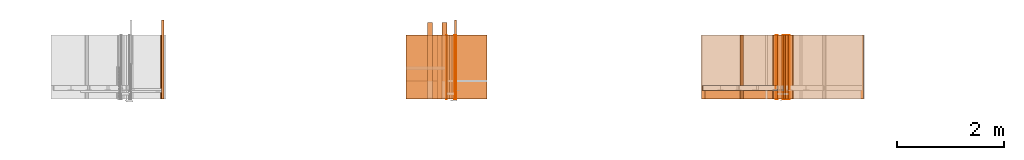
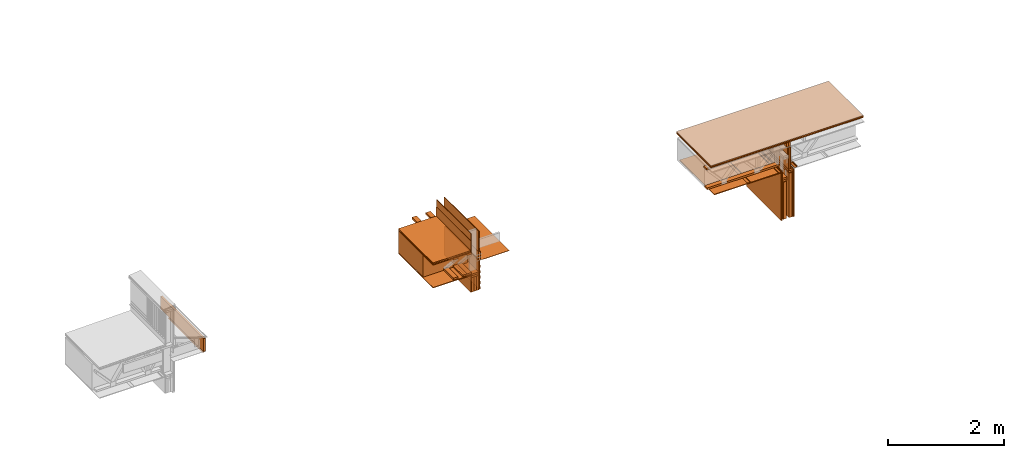
# One storey, part 4 of 22: 53 proxies.
"""IFC2X3 building model written with IfcOpenShell, lengths in feet."""

from ifc_helpers import new_model, entity, si_unit, converted_unit, frame, frame_2d, origin_with_axes, place, context, subcontext, project, spatial, polyline, rectangle, outline, extrude, element, save


model = new_model("IFC2X3")

# Units and contexts
model_context = context("Model", 3, precision=1e-05)
plan_context = context("Plan", 2, precision=1e-05, world=frame_2d((0.0, 0.0, 0.0), x_axis=(1.0, 0.0, 0.0)))
body_context_1 = subcontext(model_context, "Body", "Model", "MODEL_VIEW")
body_context_2 = subcontext(model_context, "Body", "Model", "MODEL_VIEW")
ifc_project = project(units=[converted_unit("VOLUMEUNIT", "cubic foot", entity("IfcReal", 0.0283168467116885), si_unit("VOLUMEUNIT", "CUBIC_METRE"), dimensions=[3, 0, 0, 0, 0, 0, 0]), converted_unit("AREAUNIT", "square foot", entity("IfcReal", 0.09290304), si_unit("AREAUNIT", "SQUARE_METRE"), dimensions=[2, 0, 0, 0, 0, 0, 0]), converted_unit("LENGTHUNIT", "foot", entity("IfcReal", 0.3048), si_unit("LENGTHUNIT", "METRE"), dimensions=[1, 0, 0, 0, 0, 0, 0])], contexts=[model_context, plan_context])

# Site, building, storey
site_placement = place(None, origin_with_axes())
site = spatial("IfcSite", under=ifc_project, at=site_placement, CompositionType="ELEMENT")
building_placement = place(site_placement, origin_with_axes())
building = spatial("IfcBuilding", under=site, at=building_placement, Name="Building", CompositionType="ELEMENT")
storey_placement = place(building_placement, origin_with_axes())
storey = spatial("IfcBuildingStorey", under=building, at=storey_placement, Name="Storey", CompositionType="ELEMENT")

# Proxies
proxy_1_placement = place(storey_placement, frame((1618.09265457113, 0.777434645675299, -60.9125365109581), z_axis=(0.0, 0.0, 1.0), x_axis=(1.0, 0.0, 0.0)))
element("IfcBuildingElementProxy", 1, at=proxy_1_placement, inside=storey, Name="Generic Models 857:Generic Models 1", context=body_context_1, shape_type="SweptSolid", body=[
    extrude(rectangle(XDim=4.86265082448443, YDim=0.124999990210441, at=frame_2d((0.0, 0.0, 0.0))), frame((-0.0624994935560727, 3.5449389241186, 0.0490916934441237), z_axis=(9.77766489995702e-08, -1.40081910711431e-14, -1.0), x_axis=(-1.43267257612933e-07, -1.0, 0.0)), (1.00845714001707e-08, 2.48565811489243e-07, -1.0), 0.887908264680847),
])
proxy_2_placement = place(storey_placement, frame((1617.96549799561, 1.89110167383209, -60.8823618550939), z_axis=(0.0, 0.0, 1.0), x_axis=(1.0, 0.0, 0.0)))
element("IfcBuildingElementProxy", 2, at=proxy_2_placement, inside=storey, Name="Vert", context=body_context_2, shape_type="SweptSolid", body=[
    extrude(outline(polyline([(0.00423777361432203, -0.0192872383032884), (0.10290118349897, -0.0192872383032884), (0.102901171276888, -0.0140460967660693), (0.00714266283457165, -0.0140460937105491), (-0.0136906679553466, 0.0192872367755283), (-0.0934482654776629, 0.0192872428865688), (-0.093448277699744, 0.0140460937105491), (-0.0165955587033564, 0.0140460967660693), (0.00423777361432203, -0.0192872383032884)])), frame((0.024263082766353, 3.92579930660919, -0.00037126060699912), z_axis=(0.0, 1.0, -5.34209793841001e-05), x_axis=(1.0, 0.0, -4.64536995536946e-08)), (4.39304799135232e-12, 5.34205901203677e-05, -1.0), 3.92582974397205),
])
proxy_3_placement = place(storey_placement, frame((1634.61059410115, 2.69422185389701, -61.9758708583401), z_axis=(0.0, 0.0, 1.0), x_axis=(-1.62920684942947e-07, 1.0, 0.0)))
element("IfcBuildingElementProxy", 3, at=proxy_3_placement, inside=storey, Name="Generic Models 855:Generic Models 1", context=body_context_1, shape_type="SweptSolid", body=[
    extrude(rectangle(XDim=4.70100164291481, YDim=0.291666664589754, at=frame_2d((0.0, 0.0, 0.0))), frame((1.54728593006535, 0.145833528651966, 1.70833482517032), z_axis=(0.0, 0.0, -1.0), x_axis=(1.0, 0.0, 0.0)), (0.0, 0.0, -1.0), 0.125000015272121),
])
proxy_4_placement = place(storey_placement, frame((1634.61059410115, 2.69422185389701, -61.6425354023931), z_axis=(0.0, 0.0, 1.0), x_axis=(-1.62920684942947e-07, 1.0, 0.0)))
element("IfcBuildingElementProxy", 4, at=proxy_4_placement, inside=storey, Name="Generic Models 855:Generic Models 1", context=body_context_1, shape_type="SweptSolid", body=[
    extrude(rectangle(XDim=4.70100164291481, YDim=0.291666664589754, at=frame_2d((0.0, 0.0, 0.0))), frame((1.54728593006535, 0.145833528651966, 0.0), z_axis=(0.0, 0.0, -1.0), x_axis=(1.0, 0.0, 0.0)), (0.0, 0.0, -1.0), 0.125000000235113),
])
proxy_5_placement = place(storey_placement, frame((1636.21777311711, 0.875491228472842, -58.3669457222846), z_axis=(0.0, 0.0, 1.0), x_axis=(1.0, 0.0, 0.0)))
element("IfcBuildingElementProxy", 5, at=proxy_5_placement, inside=storey, Name="Plane", context=body_context_1, shape_type="SweptSolid", body=[
    extrude(rectangle(XDim=0.0416667373353818, YDim=3.92583333372057, at=frame_2d((0.0, 0.0, 0.0))), frame((-0.729220980421452, 2.97847343242075, -1.71309029023478), z_axis=(0.0, 0.0, -1.0), x_axis=(-1.0, 0.0, 0.0)), (-7.93780046137726e-08, 0.0, -1.0), 1.23178509935517),
])
proxy_6_placement = place(storey_placement, frame((1635.25939300617, 0.875491228472842, -57.8051164081403), z_axis=(0.0, 0.0, 1.0), x_axis=(1.0, 0.0, 0.0)))
element("IfcBuildingElementProxy", 6, at=proxy_6_placement, inside=storey, Name="Plane", context=body_context_1, shape_type="SweptSolid", body=[
    extrude(rectangle(XDim=3.92583333372057, YDim=0.0416667373353818, at=frame_2d((0.0, 0.0, 0.0))), frame((0.729220980421452, 2.97847343242075, -2.46242118945585), z_axis=(0.0, 0.0, -1.0), x_axis=(0.0, -1.0, 0.0)), (0.0, 6.88914028046383e-08, -1.0), 1.41928670348369),
])
proxy_7_placement = place(storey_placement, frame((1632.20393063202, 1.89104789667555, -60.1425383660424), z_axis=(0.0, 0.0, 1.0), x_axis=(1.0, 0.0, 0.0)))
element("IfcBuildingElementProxy", 7, at=proxy_7_placement, inside=storey, Name="Generic Models 841:Generic Models 1:245", context=body_context_1, shape_type="SweptSolid", body=[
    extrude(rectangle(XDim=2.52925424444821, YDim=3.92583333372057, at=frame_2d((0.0, 0.0, 0.0))), frame((2.04088298354562, 1.96291666644139, 0.0), z_axis=(0.0, 0.0, -1.0), x_axis=(-1.0, 0.0, 0.0)), (0.0, 0.0, -1.0), 0.0625000001175565),
])
for number, where, z_axis, x_axis, name in (
    (8, (1635.96776526744, 1.8910506344217, -61.6425354023931), (0.0, 0.0, 1.0), (1.0, 0.0, 0.0), "Generic Models 857:Generic Models 1"),
    (9, (1635.96776526744, 1.8910506344217, -61.7675330695205), (0.0, 0.0, 1.0), (1.0, 0.0, 0.0), "Generic Models 857:Generic Models 1"),
):
    element("IfcBuildingElementProxy", number, at=place(storey_placement, frame(where, z_axis=z_axis, x_axis=x_axis)), inside=storey, Name=name, context=body_context_1, shape_type="SweptSolid", body=[
        extrude(rectangle(XDim=3.92583333372062, YDim=0.458337028879998, at=frame_2d((0.0, 0.0, 0.0))), frame((-0.22916851707018, 1.96291666644139, -0.124999744881169), z_axis=(2.39995301853924e-07, 1.5877549230936e-07, -1.0), x_axis=(0.0, 1.0, 1.5877549230936e-07)), (3.58418373105907e-13, 1.95553198523157e-07, -1.0), 0.125000025296795),
    ])
for number, where, z_axis, x_axis, name in (
    (10, (1635.8300957467, 1.891050829975, -62.7675331796561), (0.0, 0.0, 1.0), (1.0, 0.0, 0.0), "Generic Models 857:Generic Models 1"),
    (11, (1635.98258351404, 1.891050829975, -62.7675331796561), (0.0, 0.0, 1.0), (1.0, 0.0, 0.0), "Generic Models 857:Generic Models 1"),
    (12, (1636.13597239096, 1.891050829975, -62.7675331796561), (0.0, 0.0, 1.0), (1.0, 0.0, 0.0), "Generic Models 857:Generic Models 1"),
):
    element("IfcBuildingElementProxy", number, at=place(storey_placement, frame(where, z_axis=z_axis, x_axis=x_axis)), inside=storey, Name=name, context=body_context_1, shape_type="SweptSolid", body=[
        extrude(rectangle(XDim=3.92583333372062, YDim=0.152474618603812, at=frame_2d((0.0, 0.0, 0.0))), frame((-0.244431207420945, 1.96291666644139, -0.124999744881169), z_axis=(3.20632494776874e-07, 1.61888749516947e-07, -1.0), x_axis=(0.0, 1.0, 1.61888735306093e-07)), (-2.49453904643815e-07, 2.80553450693333e-07, -1.0), 1.00000000188097),
    ])
proxy_8_placement = place(storey_placement, frame((1635.25939300617, 0.875491228472842, -61.6011469382939), z_axis=(0.0, 0.0, 1.0), x_axis=(1.0, 0.0, 0.0)))
element("IfcBuildingElementProxy", 13, at=proxy_8_placement, inside=storey, Name="Plane", context=body_context_1, shape_type="SweptSolid", body=[
    extrude(rectangle(XDim=3.92583333372057, YDim=0.0416667373353818, at=frame_2d((0.0, 0.0, 0.0))), frame((0.729220980421452, 2.97847343242075, -1.29138547291593), z_axis=(0.0, 0.0, -1.0), x_axis=(0.0, 1.0, 0.0)), (0.0, -4.83804178941227e-08, -1.0), 2.0209963793876),
])
proxy_9_placement = place(storey_placement, frame((1632.24558191975, 1.8910506344217, -61.7362820883123), z_axis=(0.0, 0.0, 1.0), x_axis=(1.0, 0.0, 0.0)))
element("IfcBuildingElementProxy", 14, at=proxy_9_placement, inside=storey, Name="Generic Models 847:Generic Models 1:245", context=body_context_1, shape_type="SweptSolid", body=[
    extrude(rectangle(XDim=2.52916977314839, YDim=3.92583333372057, at=frame_2d((0.0, 0.0, 0.0))), frame((1.99918945630391, 1.96291666644139, 0.0), z_axis=(0.0, 0.0, -1.0), x_axis=(1.0, 0.0, 0.0)), (0.0, 0.0, -1.0), 0.0520833335148361),
])
proxy_10_placement = place(storey_placement, frame((1635.45733674618, 1.8910504388684, -63.2148777718932), z_axis=(0.0, 0.0, 1.0), x_axis=(1.0, 0.0, 0.0)))
element("IfcBuildingElementProxy", 15, at=proxy_10_placement, inside=storey, Name="Generic Models 845:Generic Models 1", context=body_context_1, shape_type="SweptSolid", body=[
    extrude(rectangle(XDim=3.92583333372062, YDim=0.0520833154704227, at=frame_2d((0.0, 0.0, 0.0))), frame((0.0260413466681411, 1.96291666644139, 0.322346925109703), z_axis=(0.0, 0.0, -1.0), x_axis=(1.63445363909887e-07, -1.0, 0.0)), (3.6811558246086e-09, 0.0, -1.0), 1.15625032746861),
])
proxy_11_placement = place(storey_placement, frame((1636.01442271956, 1.89101856368107, -60.8915669398671), z_axis=(0.0, 0.0, 1.0), x_axis=(1.0, 0.0, 0.0)))
element("IfcBuildingElementProxy", 16, at=proxy_11_placement, inside=storey, Name="Vert", context=body_context_2, shape_type="SweptSolid", body=[
    extrude(outline(polyline([(-0.0627850319241758, -0.0271161442519877), (0.120581120369941, -0.0271161442519877), (0.120581120369941, -0.0218750011870085), (-0.0575438858036763, -0.0218750011870085), (-0.0575438858036763, 0.0218750042425288), (-0.00025222097521066, 0.0218750042425288), (-0.00025222097521066, 0.0271161381409472), (-0.0627850319241758, 0.0271161381409472), (-0.0627850319241758, -0.0271161442519877)])), frame((0.0270833340754581, -4.1102113838438e-07, -0.0627715631908788), z_axis=(-3.93597567732717e-12, -1.0, -4.92744720759219e-06), x_axis=(0.0, 4.92744720759219e-06, -1.0)), (7.73744956994449e-10, -3.93597567732717e-12, -1.0), 3.92586307694604),
])
proxy_12_placement = place(storey_placement, frame((1635.08237503332, 0.875493770665697, -59.9454707048071), z_axis=(0.0, 0.0, 1.0), x_axis=(1.0, 0.0, 0.0)))
element("IfcBuildingElementProxy", 17, at=proxy_12_placement, inside=storey, Name="Plane", context=body_context_1, shape_type="SweptSolid", body=[
    extrude(rectangle(XDim=2.88351197437853, YDim=2.81717074082157, at=frame_2d((0.0, 0.0, 0.0))), frame((-0.660401668761346, 3.53280484207033, -1.69706332871294), z_axis=(0.0, 0.0, -1.0), x_axis=(1.0, 0.0, 0.0)), (0.0, 0.0, -1.0), 1.49999431547957),
])
proxy_13_placement = place(storey_placement, frame((1636.01962913053, 5.81688142511163, -63.8967924543566), z_axis=(0.0, -1.0, -1.62920684942947e-07), x_axis=(1.0, 0.0, 0.0)))
element("IfcBuildingElementProxy", 18, at=proxy_13_placement, inside=storey, Name="Plane", context=body_context_1, shape_type="SweptSolid", body=[
    extrude(outline(polyline([(-0.249999685315635, -0.0130000119060865), (0.24999939198569, -0.0130000073228061), (0.249999807536446, 0.0129999844064041), (-0.249999245320718, 0.0129999569067218), (-0.249999685315635, -0.0130000119060865)])), frame((0.0304482135374167, 2.75151720979395, -1.91897533617344e-05), z_axis=(-0.000177675639861263, -4.37063754361589e-05, -1.0), x_axis=(0.0697632730007172, -0.997563600540161, 3.12046613544226e-05)), (2.26211595872883e-05, 0.000180287868715823, -1.0), 3.9300003207006),
])
proxy_14_placement = place(storey_placement, frame((1636.00941655517, 1.89101856368107, -60.8915669398671), z_axis=(0.0, 0.0, 1.0), x_axis=(1.0, 0.0, 0.0)))
element("IfcBuildingElementProxy", 19, at=proxy_14_placement, inside=storey, Name="Vert", context=body_context_2, shape_type="SweptSolid", body=[
    extrude(outline(polyline([(-1.96293152849192, -0.00262057153248959), (1.96293152849192, -0.00262057153248959), (1.96293152849192, 0.00262057172345961), (-1.96293152849192, 0.00262057172345961), (-1.96293152849192, -0.00262057153248959)])), frame((0.00258776135595999, 1.96293152849192, -2.0009652757895), z_axis=(0.0, 0.0, -1.0), x_axis=(0.0, -1.0, 0.0)), (0.0, 0.0, -1.0), 2.02099423655302),
])
proxy_15_placement = place(storey_placement, frame((1634.96092548521, 1.89104789667555, -60.8915356513396), z_axis=(0.0, 0.0, 1.0), x_axis=(1.0, 0.0, 0.0)))
element("IfcBuildingElementProxy", 20, at=proxy_15_placement, inside=storey, Name="Generic Models 841:Generic Models 1:245", context=body_context_1, shape_type="SweptSolid", body=[
    extrude(rectangle(XDim=1.95334235530076, YDim=3.92583333372057, at=frame_2d((0.0, 0.0, 0.0))), frame((2.03011973010586, 1.96291666644139, 0.0), z_axis=(0.0, 0.0, -1.0), x_axis=(1.0, 0.0, 0.0)), (0.0, 0.0, -0.999999940395355), 0.0199999997321788),
])
proxy_16_placement = place(storey_placement, frame((1634.53039534762, 0.875502863893984, -58.0819322681177), z_axis=(-0.0622692182660103, -0.998051941394806, 0.00389242777600884), x_axis=(0.996106803417206, -0.0623907446861267, -0.06227657943964)))
element("IfcBuildingElementProxy", 21, at=proxy_16_placement, inside=storey, Name="Plane", context=body_context_1, shape_type="SweptSolid", body=[
    extrude(rectangle(XDim=0.0830000892507013, YDim=2.48751138231626, at=frame_2d((0.0, 0.0, 0.0))), frame((-0.491706053103049, -1.97191935355269, -4.92030867128547), z_axis=(-0.0623725615441799, 9.7108348029451e-08, -0.998052954673767), x_axis=(0.0622801221907139, -0.998051106929779, -0.0038922131061554)), (1.44668717894092e-06, -7.77533568907529e-06, -1.0), 3.92583022876836),
])
proxy_17_placement = place(storey_placement, frame((1632.19081448132, 1.89105493659422, -60.3577283423717), z_axis=(-0.0623933188617229, 0.998051643371582, -7.58967132696853e-07), x_axis=(-0.998051643371582, -0.0623933188617229, -1.47461420851869e-07)))
element("IfcBuildingElementProxy", 22, at=proxy_17_placement, inside=storey, Name="Generic Models 849:Generic Models 1", context=body_context_1, shape_type="SweptSolid", body=[
    extrude(outline(polyline([(-0.822174502169992, 0.213420341216673), (1.65544997832281, 0.213420341216673), (1.65482381666739, 0.223400721478024), (-0.832781019642597, 0.222774315380988), (-0.832648043400972, -0.436509081854282), (-0.822669154233507, -0.436506588549752), (-0.822174502169992, 0.213420341216673)])), frame((-2.43948630773489, 0.583672324034173, -0.152505049359767), z_axis=(0.0624201260507107, 1.42673263781035e-06, -0.998049974441528), x_axis=(0.998049974441528, 0.000251227029366419, 0.0624199658632278)), (1.3117592970957e-05, -1.32989362100489e-06, -1.0), 3.92583366091166),
])
proxy_18_placement = place(storey_placement, frame((1652.03174581052, 2.42488121423196, -61.6425354023931), z_axis=(0.0, 0.0, 1.0), x_axis=(1.0, 0.0, 0.0)))
element("IfcBuildingElementProxy", 23, at=proxy_18_placement, inside=storey, Name="Generic Models 855:Generic Models 1", context=body_context_1, shape_type="SweptSolid", body=[
    extrude(rectangle(XDim=4.68458124684587, YDim=0.291666664589754, at=frame_2d((0.0, 0.0, 0.0))), frame((1.53907582046479, 0.145833528651966, 0.0), z_axis=(0.0, 0.0, -1.0), x_axis=(1.0, 0.0, 0.0)), (0.0, 0.0, -1.0), 0.125000000235113),
])
proxy_19_placement = place(storey_placement, frame((1655.84704381587, 1.89104789667555, -62.3925401782739), z_axis=(0.0, 0.0, 1.0), x_axis=(-1.62920684942947e-07, 1.0, 0.0)))
element("IfcBuildingElementProxy", 24, at=proxy_19_placement, inside=storey, Name="Generic Models 857:Generic Models 1", context=body_context_1, shape_type="SweptSolid", body=[
    extrude(rectangle(XDim=0.291681873054029, YDim=3.92583333372057, at=frame_2d((0.0, 0.0, 0.0))), frame((1.96291666644139, -0.145840935233071, 0.125000001544871), z_axis=(0.0, 0.0, -1.0), x_axis=(0.0, 1.0, 0.0)), (0.0, 0.0, -1.0), 0.125000000235113),
])
proxy_20_placement = place(storey_placement, frame((1656.61949498134, 1.89104809222885, -61.6842117209447), z_axis=(0.0, 0.0, 1.0), x_axis=(-1.62920684942947e-07, 1.0, 0.0)))
element("IfcBuildingElementProxy", 25, at=proxy_20_placement, inside=storey, Name="Dowel60:Dowel", context=body_context_1, shape_type="SweptSolid", body=[
    extrude(outline(polyline([(-0.0601568078412002, 0.0312148619032516), (-0.00859693082641038, 0.0312148557922111), (0.0745830922986422, -0.0519651719161219), (0.0745830984096827, -0.0792705964815272), (0.0797914282426121, -0.0792705964815272), (0.0797914282426121, -0.049807809615933), (-0.00643956241518103, 0.036423191736181), (-0.0579994333189303, 0.0364231856251404), (-0.085936733362634, 0.0643604765022834), (-0.0896195763736729, 0.0606776334912445), (-0.0601568078412002, 0.0312148619032516)])), frame((7.80471796843667e-07, -0.112483185029092, 0.0211991903829215), z_axis=(-1.0, -2.10234720725566e-05, -1.15315469884081e-05), x_axis=(-6.7118080551154e-06, 0.70710676908493, -0.707106828689575)), (-5.45950661035022e-06, 2.0893143300782e-05, -1.0), 3.92583333463594),
])
proxy_21_placement = place(storey_placement, frame((1651.7534030704, 1.89104731001566, -61.6842117209447), z_axis=(0.0, 0.0, 1.0), x_axis=(-1.62920684942947e-07, 1.0, 0.0)))
element("IfcBuildingElementProxy", 26, at=proxy_21_placement, inside=storey, Name="Dowel60:Dowel", context=body_context_1, shape_type="SweptSolid", body=[
    extrude(outline(polyline([(-0.106276262287549, -0.0204650466415904), (-0.0646095319585068, -0.0204650466415904), (-0.0281511559065558, 0.0159932896885972), (0.0894831473941565, 0.0159932835775567), (0.108790906571497, -0.0033145642098714), (0.112473761804617, 0.000368273883689503), (0.0916404913612238, 0.0212016225770468), (-0.0303084998736231, 0.0212016195215265), (-0.0667668759255741, -0.0152567168086611), (-0.106276262287549, -0.0152567106976206), (-0.106276262287549, -0.0204650466415904)])), frame((3.92583411509596, -1.88752617735875, 0.0212016454934487), z_axis=(1.0, -1.44433724926785e-05, 5.75471631236724e-07), x_axis=(-9.38654284254881e-06, -1.0, -7.33323659574125e-08)), (7.52120149627444e-06, -5.71511520774948e-07, -1.0), 3.92583333383225),
])
proxy_22_placement = place(storey_placement, frame((1656.22210565202, 1.89104789667555, -62.0175471768917), z_axis=(0.0, 0.0, 1.0), x_axis=(-1.62920684942947e-07, 1.0, 0.0)))
element("IfcBuildingElementProxy", 27, at=proxy_22_placement, inside=storey, Name="Generic Models 857:Generic Models 1", context=body_context_1, shape_type="SweptSolid", body=[
    extrude(rectangle(XDim=0.291681873054029, YDim=3.92583333372057, at=frame_2d((0.0, 0.0, 0.0))), frame((1.96291666644139, -0.145840935233071, 0.125000001544871), z_axis=(0.0, 0.0, -1.0), x_axis=(0.0, 1.0, 0.0)), (0.0, 0.0, -1.0), 0.125000000235113),
])
proxy_23_placement = place(storey_placement, frame((1653.75336574444, 1.89104770112225, -61.6842117209447), z_axis=(0.0, 0.0, 1.0), x_axis=(-1.62920684942947e-07, 1.0, 0.0)))
element("IfcBuildingElementProxy", 28, at=proxy_23_placement, inside=storey, Name="Dowel60:Dowel", context=body_context_1, shape_type="SweptSolid", body=[
    extrude(outline(polyline([(-0.0916406685813988, -0.0212016195215265), (0.0303083257089684, -0.0212016195215265), (0.0667666987053991, 0.0152567152809009), (0.106276091178415, 0.0152567076421003), (0.106276091178415, 0.0204650435860701), (0.0646093547383318, 0.0204650451138303), (0.0281509817419011, -0.0159932896885972), (-0.0894833246143315, -0.0159932805220364), (-0.108791077680632, 0.00331456764733169), (-0.112473932913751, -0.000368270422357961), (-0.0916406685813988, -0.0212016195215265)])), frame((3.92583411509596, -1.88752617735875, 0.0212016454934487), z_axis=(1.0, -1.40156489578658e-05, -4.35728196634955e-07), x_axis=(1.28285309983767e-05, 1.0, 9.83910126706178e-08)), (-5.92708465774194e-06, -4.39525564388532e-07, -1.0), 3.92583333378991),
])
proxy_24_placement = place(storey_placement, frame((1655.80539252814, 0.875491326249491, -62.9761525652227), z_axis=(0.0, 0.0, 1.0), x_axis=(1.0, 0.0, 0.0)))
element("IfcBuildingElementProxy", 29, at=proxy_24_placement, inside=storey, Name="Plane", context=body_context_1, shape_type="SweptSolid", body=[
    extrude(rectangle(XDim=0.208333394207372, YDim=3.92583333372057, at=frame_2d((0.0, 0.0, 0.0))), frame((0.56250001306296, 2.97847343242075, -2.03039878465998), z_axis=(0.0, 0.0, -1.0), x_axis=(-1.0, 0.0, 0.0)), (0.0, 0.0, -1.0), 3.07234290048816),
])
proxy_25_placement = place(storey_placement, frame((1655.80539252814, 0.875491326249491, -63.4761557491433), z_axis=(0.0, 0.0, 1.0), x_axis=(1.0, 0.0, 0.0)))
element("IfcBuildingElementProxy", 30, at=proxy_25_placement, inside=storey, Name="Plane", context=body_context_1, shape_type="SweptSolid", body=[
    extrude(rectangle(XDim=0.208333334059344, YDim=3.92583333372057, at=frame_2d((0.0, 0.0, 0.0))), frame((0.187500020650428, 2.97847343242075, -1.53039560073943), z_axis=(0.0, 0.0, -1.0), x_axis=(-1.0, 0.0, 0.0)), (9.50269551935889e-09, 0.0, -1.0), 2.57233979441147),
])
proxy_26_placement = place(storey_placement, frame((1655.80539252814, 0.875491326249491, -62.9761525652227), z_axis=(0.0, 0.0, 1.0), x_axis=(1.0, 0.0, 0.0)))
element("IfcBuildingElementProxy", 31, at=proxy_26_placement, inside=storey, Name="Plane", context=body_context_1, shape_type="SweptSolid", body=[
    extrude(rectangle(XDim=3.92583333372057, YDim=0.0416666640300221, at=frame_2d((0.0, 0.0, 0.0))), frame((0.0208333437758794, 2.97847343242075, -2.07206552110006), z_axis=(0.0, 0.0, -1.0), x_axis=(0.0, -1.0, 0.0)), (0.0, 5.83169690315799e-09, -1.0), 3.40567790332094),
])
proxy_27_placement = place(storey_placement, frame((1655.84704381587, 1.89104789667555, -62.5175441031068), z_axis=(0.0, 0.0, 1.0), x_axis=(-1.62920684942947e-07, 1.0, 0.0)))
element("IfcBuildingElementProxy", 32, at=proxy_27_placement, inside=storey, Name="Generic Models 857:Generic Models 1", context=body_context_1, shape_type="SweptSolid", body=[
    extrude(rectangle(XDim=0.291681873054029, YDim=3.92583333372057, at=frame_2d((0.0, 0.0, 0.0))), frame((1.96291666644139, -0.145840935233071, 0.125000001544871), z_axis=(0.0, 0.0, -1.0), x_axis=(0.0, 1.0, 0.0)), (0.0, 0.0, -1.0), 0.125000000235113),
])
proxy_28_placement = place(storey_placement, frame((1655.80539252814, 0.875491326249491, -62.9761588229282), z_axis=(0.0, 0.0, 1.0), x_axis=(1.0, 0.0, 0.0)))
element("IfcBuildingElementProxy", 33, at=proxy_28_placement, inside=storey, Name="Plane", context=body_context_1, shape_type="SweptSolid", body=[
    extrude(rectangle(XDim=3.92583333372057, YDim=0.0416667373353818, at=frame_2d((0.0, 0.0, 0.0))), frame((0.729220980421452, 2.97847343242075, -2.07206552110006), z_axis=(0.0, 0.0, -1.0), x_axis=(0.0, 1.0, 0.0)), (0.0, -1.4354937682981e-08, -1.0), 3.40567997555669),
])
proxy_29_placement = place(storey_placement, frame((1655.75332841848, 1.89104789667555, -65.0482227796019), z_axis=(0.0, 0.0, 1.0), x_axis=(-1.62920684942947e-07, 1.0, 0.0)))
element("IfcBuildingElementProxy", 34, at=proxy_29_placement, inside=storey, Name="Generic Models 845:Generic Models 1", context=body_context_1, shape_type="SweptSolid", body=[
    extrude(rectangle(XDim=3.92583333372057, YDim=0.052083273366765, at=frame_2d((0.0, 0.0, 0.0))), frame((1.96291666644139, -0.82807121627287, 0.0), z_axis=(0.0, 0.0, -1.0), x_axis=(1.0, 0.0, 0.0)), (0.0, 0.0, -1.0), 3.31192968589252),
])
proxy_30_placement = place(storey_placement, frame((1652.54157359206, 1.89104789667555, -61.7362946037232), z_axis=(0.0, 0.0, 1.0), x_axis=(1.0, 0.0, 0.0)))
element("IfcBuildingElementProxy", 35, at=proxy_30_placement, inside=storey, Name="Generic Models 847:Generic Models 1:245", context=body_context_1, shape_type="SweptSolid", body=[
    extrude(rectangle(XDim=4.43001041812591, YDim=3.92583333372057, at=frame_2d((0.0, 0.0, 0.0))), frame((1.04876914675154, 1.96291666644139, 0.0), z_axis=(0.0, 0.0, -1.0), x_axis=(0.999999940395355, 0.0, 0.0)), (0.0, 0.0, -1.0), 0.0520833335148361),
])
proxy_31_placement = place(storey_placement, frame((1655.75332841848, 1.89104789667555, -65.0482227796019), z_axis=(0.0, 0.0, 1.0), x_axis=(-1.62920684942947e-07, 1.0, 0.0)))
element("IfcBuildingElementProxy", 36, at=proxy_31_placement, inside=storey, Name="Generic Models 845:Generic Models 1", context=body_context_1, shape_type="SweptSolid", body=[
    extrude(rectangle(XDim=3.92583333372057, YDim=0.0520833335148361, at=frame_2d((0.0, 0.0, 0.0))), frame((1.96291666644139, -0.0260416674977682, 0.0), z_axis=(0.0, 0.0, -1.0), x_axis=(1.0, 0.0, 0.0)), (0.0, 0.0, -1.0), 3.31192968589252),
])
proxy_32_placement = place(storey_placement, frame((1656.22210565202, 1.89104789667555, -61.8925432520589), z_axis=(0.0, 0.0, 1.0), x_axis=(-1.62920684942947e-07, 1.0, 0.0)))
element("IfcBuildingElementProxy", 37, at=proxy_32_placement, inside=storey, Name="Generic Models 857:Generic Models 1", context=body_context_1, shape_type="SweptSolid", body=[
    extrude(rectangle(XDim=0.291681873054029, YDim=3.92583333372057, at=frame_2d((0.0, 0.0, 0.0))), frame((1.96291666644139, -0.145840935233071, 0.125000001544871), z_axis=(0.0, 0.0, -1.0), x_axis=(0.0, -1.0, 0.0)), (0.0, 0.0, -1.0), 0.125000000235113),
])
proxy_33_placement = place(storey_placement, frame((1656.2115927068, 1.8910506344217, -59.8092091678009), z_axis=(0.0, 0.0, 1.0), x_axis=(1.0, 0.0, 0.0)))
element("IfcBuildingElementProxy", 38, at=proxy_33_placement, inside=storey, Name="Generic Models 857:Generic Models 1", context=body_context_1, shape_type="SweptSolid", body=[
    extrude(rectangle(XDim=3.92583333372062, YDim=0.103999983757077, at=frame_2d((0.0, 0.0, 0.0))), frame((0.0624996646652071, 1.96291666644139, -1.83333014565816), z_axis=(0.0, 0.0, -1.0), x_axis=(-1.61888735306093e-07, 1.0, 0.0)), (-6.74533007227751e-09, 1.62961075744761e-08, -0.999999940395355), 1.49999998277201),
])
proxy_34_placement = place(storey_placement, frame((1656.17004154235, 1.89104789667555, -63.5482132278402), z_axis=(0.0, 0.0, 1.0), x_axis=(-1.62920684942947e-07, 1.0, 0.0)))
element("IfcBuildingElementProxy", 39, at=proxy_34_placement, inside=storey, Name="Generic Models 845:Generic Models 1", context=body_context_1, shape_type="SweptSolid", body=[
    extrude(rectangle(XDim=3.92583333372057, YDim=0.0520833335148361, at=frame_2d((0.0, 0.0, 0.0))), frame((1.96291666644139, -0.0260416674977682, 2.90568419328825), z_axis=(0.0, 0.0, -1.0), x_axis=(1.0, 0.0, 0.0)), (0.0, 0.0, -1.0), 0.499992241783544),
])
proxy_35_placement = place(storey_placement, frame((1655.52414621268, 1.89104789667555, -63.5482132278402), z_axis=(0.0, 0.0, 1.0), x_axis=(-1.62920684942947e-07, 1.0, 0.0)))
element("IfcBuildingElementProxy", 40, at=proxy_35_placement, inside=storey, Name="Generic Models 845:Generic Models 1", context=body_context_1, shape_type="SweptSolid", body=[
    extrude(rectangle(XDim=3.92583333372057, YDim=0.052083273366765, at=frame_2d((0.0, 0.0, 0.0))), frame((1.96291666644139, -0.82807121627287, 1.90567156774165), z_axis=(0.0, 0.0, -1.0), x_axis=(1.0, 0.0, 0.0)), (0.0, 0.0, -1.0), 1.50000484807202),
])
for number, where, z_axis, x_axis, name in (
    (41, (1655.97269854208, 1.89105591436071, -59.7883459777031), (1.0, 4.01339377731347e-07, -4.01339264044509e-07), (-4.01339264044509e-07, 1.0, 2.68220873067548e-07), "Generic Models 857:Generic Models 1"),
    (42, (1656.09775252855, 1.89105591436071, -59.7883459777031), (1.0, 4.01339377731347e-07, -4.01339264044509e-07), (-4.01339264044509e-07, 1.0, 2.68220873067548e-07), "Generic Models 857:Generic Models 1"),
):
    element("IfcBuildingElementProxy", number, at=place(storey_placement, frame(where, z_axis=z_axis, x_axis=x_axis)), inside=storey, Name=name, context=body_context_1, shape_type="SweptSolid", body=[
        extrude(rectangle(XDim=0.291681873054029, YDim=3.92583333372057, at=frame_2d((0.0, 0.0, 0.0))), frame((1.96291666644139, -0.145840935233071, 0.125000001544871), z_axis=(0.0, 0.0, -1.0), x_axis=(0.0, -1.0, 0.0)), (0.0, 0.0, -1.0), 0.125000000235113),
    ])
for number, where, z_axis, x_axis, name in (
    (43, (1636.01962913053, 5.81688142511163, -64.2685001603574), (0.0, -1.0, -1.62920684942947e-07), (1.0, 0.0, 0.0), "Plane"),
    (44, (1636.01962913053, 5.81688142511163, -64.6394006223503), (0.0, -1.0, -1.62920684942947e-07), (1.0, 0.0, 0.0), "Plane"),
    (45, (1636.01962913053, 5.81688142511163, -65.0105201040353), (0.0, -1.0, -1.62920684942947e-07), (1.0, 0.0, 0.0), "Plane"),
    (46, (1636.01962913053, 5.81688142511163, -65.3818711208233), (0.0, -1.0, -1.62920684942947e-07), (1.0, 0.0, 0.0), "Plane"),
):
    element("IfcBuildingElementProxy", number, at=place(storey_placement, frame(where, z_axis=z_axis, x_axis=x_axis)), inside=storey, Name=name, context=body_context_1, shape_type="SweptSolid", body=[
        extrude(outline(polyline([(-0.249999685315635, -0.0130000119060865), (0.24999939198569, -0.0130000073228061), (0.249999807536446, 0.0129999844064041), (-0.249999245320718, 0.0129999569067218), (-0.249999685315635, -0.0130000119060865)])), frame((0.0304482135374167, 2.75151720979395, -1.91897533617344e-05), z_axis=(-0.000177675639861263, -4.37063754361589e-05, -1.0), x_axis=(0.0697632730007172, -0.997563600540161, 3.12046613544226e-05)), (2.26211595872883e-05, 0.000180287868715823, -1.0), 3.9300003207006),
    ])
proxy_36_placement = place(storey_placement, frame((1634.92608258105, 1.89104789667555, -61.7675330695205), z_axis=(0.0, 0.0, 1.0), x_axis=(-1.62920684942947e-07, 1.0, 0.0)))
element("IfcBuildingElementProxy", 47, at=proxy_36_placement, inside=storey, Name="Generic Models 857:Generic Models 1", context=body_context_1, shape_type="SweptSolid", body=[
    extrude(rectangle(XDim=0.291681873054029, YDim=3.92583333372057, at=frame_2d((0.0, 0.0, 0.0))), frame((1.96291666644139, -0.145840935233071, 0.125000001544871), z_axis=(0.0, 0.0, -1.0), x_axis=(0.0, 1.0, 0.0)), (0.0, 0.0, -1.0), 0.125000000235113),
])
proxy_37_placement = place(storey_placement, frame((1635.50940085584, 2.69422185389701, -61.9758708583401), z_axis=(0.0, 0.0, 1.0), x_axis=(-1.62920684942947e-07, 1.0, 0.0)))
element("IfcBuildingElementProxy", 48, at=proxy_37_placement, inside=storey, Name="Generic Models 855:Generic Models 1", context=body_context_1, shape_type="SweptSolid", body=[
    extrude(rectangle(XDim=4.70100164291481, YDim=0.291666664589754, at=frame_2d((0.0, 0.0, 0.0))), frame((1.54728593006535, 0.145833528651966, 1.70833482517032), z_axis=(0.0, 0.0, -1.0), x_axis=(-1.0, 0.0, 0.0)), (0.0, 0.0, -1.0), 0.125000015272121),
])
proxy_38_placement = place(storey_placement, frame((1635.50940085584, 2.69422185389701, -61.6425354023931), z_axis=(0.0, 0.0, 1.0), x_axis=(-1.62920684942947e-07, 1.0, 0.0)))
element("IfcBuildingElementProxy", 49, at=proxy_38_placement, inside=storey, Name="Generic Models 855:Generic Models 1", context=body_context_1, shape_type="SweptSolid", body=[
    extrude(rectangle(XDim=4.70100164291481, YDim=0.291666664589754, at=frame_2d((0.0, 0.0, 0.0))), frame((1.54728593006535, 0.145833528651966, 0.0), z_axis=(0.0, 0.0, -1.0), x_axis=(-1.0, 0.0, 0.0)), (0.0, 0.0, -1.0), 0.125000000235113),
])
proxy_39_placement = place(storey_placement, frame((1651.96586468714, 2.42488121423196, -60.2675360331698), z_axis=(0.0, 0.0, 1.0), x_axis=(1.0, 0.0, 0.0)))
element("IfcBuildingElementProxy", 50, at=proxy_39_placement, inside=storey, Name="Generic Models 855:Generic Models 1", context=body_context_1, shape_type="SweptSolid", body=[
    extrude(rectangle(XDim=5.05934271880333, YDim=0.291666664589754, at=frame_2d((0.0, 0.0, 0.0))), frame((1.72645655360435, 0.145833528651966, 0.0), z_axis=(0.0, 0.0, -1.0), x_axis=(-0.999999940395355, 0.0, 0.0)), (0.0, 0.0, -1.0), 0.125000000235113),
])
proxy_40_placement = place(storey_placement, frame((1654.30114025206, 1.89105591436071, -59.7883459777031), z_axis=(0.0, 0.0, 1.0), x_axis=(1.0, 0.0, 0.0)))
element("IfcBuildingElementProxy", 51, at=proxy_40_placement, inside=storey, Name="Generic Models 841:Generic Models 1:245", context=body_context_1, shape_type="SweptSolid", body=[
    extrude(rectangle(XDim=9.96871498681381, YDim=3.92583333372057, at=frame_2d((0.0, 0.0, 0.0))), frame((1.84589288053237, 1.96291666644139, 0.0), z_axis=(0.0, 0.0, -1.0), x_axis=(-1.0, 0.0, 0.0)), (0.0, 0.0, -1.0), 0.0625000001175565),
])
proxy_41_placement = place(storey_placement, frame((1656.62760496765, 0.875510979355789, -57.7277398797784), z_axis=(-0.0622692257165909, -0.998051822185516, 0.00389242731034756), x_axis=(0.996106803417206, -0.0623907595872879, -0.0622765868902206)))
element("IfcBuildingElementProxy", 52, at=proxy_41_placement, inside=storey, Name="Plane", context=body_context_1, shape_type="SweptSolid", body=[
    extrude(rectangle(XDim=0.0830001136070218, YDim=9.9687255397146, at=frame_2d((0.0, 0.0, 0.0))), frame((-0.665142662881866, -1.98278370804674, -4.90946680542052), z_axis=(-0.0623861886560917, -7.75410853748326e-07, -0.998052060604095), x_axis=(-0.0622848160564899, 0.998050808906555, 0.00389221217483282)), (-1.77785875621339e-06, -6.0070105973864e-06, -1.0), 3.92583055557273),
])
proxy_42_placement = place(storey_placement, frame((1636.09271913063, 0.777434450122002, -60.8390022137659), z_axis=(0.0, 0.0, 1.0), x_axis=(1.0, 0.0, 0.0)))
element("IfcBuildingElementProxy", 53, at=proxy_42_placement, inside=storey, Name="Generic Models 857:Generic Models 1", context=body_context_1, shape_type="SweptSolid", body=[
    extrude(rectangle(XDim=4.86265082448525, YDim=0.124999990210441, at=frame_2d((0.0, 0.0, 0.0))), frame((-0.0624994935560727, 3.5449389241186, -0.0325324083495093), z_axis=(1.22221237575104e-07, -5.79980962811533e-07, -1.0), x_axis=(-1.43267257612933e-07, -1.0, 5.79981019654952e-07)), (5.63567084554961e-07, 1.58625198309892e-07, -1.0), 0.60400003859525),
])

save(model, "model.ifc")
